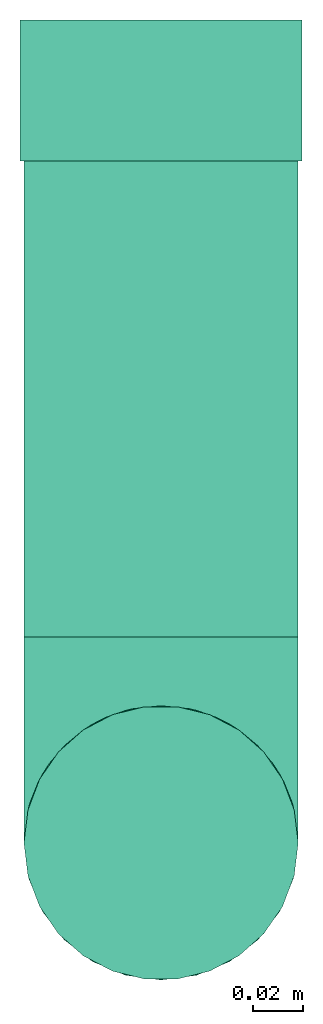
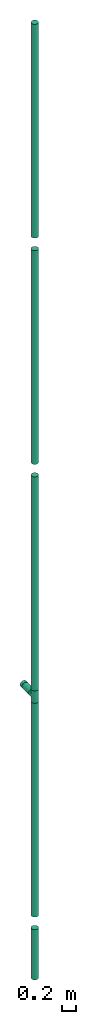
# One storey: 6 flow segments, 2 flow fittings.
"""IFC2X3 building model written with IfcOpenShell, lengths in millimetres."""

from ifc_helpers import new_model, entity, si_unit, converted_unit, derived_unit, direction, frame, frame_2d, origin, origin_2d_with_axis, place, context, subcontext, project, spatial, circle, extrude, faceted_brep, source, transform, mapped, type_object, type_shapes, element, save


model = new_model("IFC2X3")

# Units and contexts
model_context = context("Model", 3, precision=0.01, world=origin(), true_north=direction((6.12303176911189e-17, 1.0)))
body_context = subcontext(model_context, "Body", "Model", "MODEL_VIEW")
ifc_project = project(units=[si_unit("LENGTHUNIT", "METRE", prefix="MILLI"), si_unit("AREAUNIT", "SQUARE_METRE"), si_unit("VOLUMEUNIT", "CUBIC_METRE"), converted_unit("PLANEANGLEUNIT", "DEGREE", entity("IfcRatioMeasure", 0.0174532925199433), si_unit("PLANEANGLEUNIT", "RADIAN"), dimensions=[0, 0, 0, 0, 0, 0, 0]), si_unit("MASSUNIT", "GRAM", prefix="KILO"), derived_unit("MASSDENSITYUNIT", [(si_unit("MASSUNIT", "GRAM", prefix="KILO"), 1), (si_unit("LENGTHUNIT", "METRE"), -3)]), si_unit("TIMEUNIT", "SECOND"), si_unit("FREQUENCYUNIT", "HERTZ"), si_unit("THERMODYNAMICTEMPERATUREUNIT", "DEGREE_CELSIUS"), derived_unit("THERMALTRANSMITTANCEUNIT", [(si_unit("MASSUNIT", "GRAM", prefix="KILO"), 1), (si_unit("THERMODYNAMICTEMPERATUREUNIT", "KELVIN"), -1), (si_unit("TIMEUNIT", "SECOND"), -3)]), derived_unit("VOLUMETRICFLOWRATEUNIT", [(si_unit("LENGTHUNIT", "METRE"), 3), (si_unit("TIMEUNIT", "SECOND"), -1)]), si_unit("ELECTRICCURRENTUNIT", "AMPERE"), si_unit("ELECTRICVOLTAGEUNIT", "VOLT"), si_unit("POWERUNIT", "WATT"), si_unit("FORCEUNIT", "NEWTON", prefix="KILO"), si_unit("ILLUMINANCEUNIT", "LUX"), si_unit("LUMINOUSFLUXUNIT", "LUMEN"), si_unit("LUMINOUSINTENSITYUNIT", "CANDELA"), derived_unit("USERDEFINED", [(si_unit("MASSUNIT", "GRAM", prefix="KILO"), -1), (si_unit("LENGTHUNIT", "METRE"), -2), (si_unit("TIMEUNIT", "SECOND"), 3), (si_unit("LUMINOUSFLUXUNIT", "LUMEN"), 1)]), derived_unit("LINEARVELOCITYUNIT", [(si_unit("LENGTHUNIT", "METRE"), 1), (si_unit("TIMEUNIT", "SECOND"), -1)]), si_unit("PRESSUREUNIT", "PASCAL"), derived_unit("USERDEFINED", [(si_unit("LENGTHUNIT", "METRE"), -2), (si_unit("MASSUNIT", "GRAM", prefix="KILO"), 1), (si_unit("TIMEUNIT", "SECOND"), -2)])], contexts=[model_context])

# Site, building, storey
site_placement = place(None, origin())
site = spatial("IfcSite", under=ifc_project, at=site_placement, CompositionType="ELEMENT")
building_placement = place(site_placement, origin())
building = spatial("IfcBuilding", under=site, at=building_placement, CompositionType="ELEMENT")
storey_placement = place(building_placement, frame((0.0, 0.0, 4000.0)))
storey = spatial("IfcBuildingStorey", under=building, at=storey_placement, Name="01 Level", CompositionType="ELEMENT", Elevation=4000.0)

# Flow segments
pipe_segment_type = type_object("IfcPipeSegmentType", Name="Pipe Types", PredefinedType="NOTDEFINED")
flow_segment_1_placement = place(storey_placement, frame((30783.1932668086, -68217.4194628322, 9110.0)))
element("IfcFlowSegment", 1, at=flow_segment_1_placement, inside=storey, type_object=pipe_segment_type, Name="Pipe Types", ObjectType="Pipe Types", context=body_context, shape_type="SweptSolid", body=[
    extrude(circle(Radius=55.0, at=origin_2d_with_axis()), frame((56.5952722359164, 56.5952722359121, 0.0)), (0.0, 0.0, 1.0), 3780.0),
])
flow_segment_2_placement = place(storey_placement, frame((30783.1932668086, -68078.3241905963, 943.404727764084)))
element("IfcFlowSegment", 2, at=flow_segment_2_placement, inside=storey, type_object=pipe_segment_type, Name="Pipe Types", ObjectType="Pipe Types", context=body_context, shape_type="SweptSolid", body=[
    extrude(circle(Radius=55.0, at=origin_2d_with_axis()), frame((56.5952722359164, 0.0, 56.5952722359164), z_axis=(0.0, 1.0, 0.0), x_axis=(1.0, 0.0, 0.0)), (0.0, 0.0, 1.0), 190.972824049356),
])
flow_segment_3_placement = place(storey_placement, frame((30783.1932668086, -68217.4194628322, -4000.0)))
element("IfcFlowSegment", 3, at=flow_segment_3_placement, inside=storey, type_object=pipe_segment_type, Name="Pipe Types", ObjectType="Pipe Types", context=body_context, shape_type="SweptSolid", body=[
    extrude(circle(Radius=55.0, at=origin_2d_with_axis()), frame((56.5952722359164, 56.5952722359121, 0.0)), (0.0, 0.0, 1.0), 890.000000000002),
])
flow_segment_4_placement = place(storey_placement, frame((30783.1932668086, -68217.4194628322, -2890.0)))
element("IfcFlowSegment", 4, at=flow_segment_4_placement, inside=storey, type_object=pipe_segment_type, Name="Pipe Types", ObjectType="Pipe Types", context=body_context, shape_type="SweptSolid", body=[
    extrude(circle(Radius=55.0, at=origin_2d_with_axis()), frame((56.5952722359164, 56.5952722359121, 0.0)), (0.0, 0.0, 1.0), 3780.0),
])
for number, where, name in (
    (5, (30783.1932668086, -68217.4194628322, 1110.0), "Pipe Types"),
    (6, (30783.1932668086, -68217.4194628322, 5110.0), "Pipe Types"),
):
    element("IfcFlowSegment", number, at=place(storey_placement, frame(where)), inside=storey, type_object=pipe_segment_type, Name=name, ObjectType="Pipe Types", context=body_context, shape_type="SweptSolid", body=[
        extrude(circle(Radius=55.0, at=origin_2d_with_axis()), frame((56.5952722359164, 56.5952722359121, 0.0), z_axis=(0.0, 0.0, 1.0), x_axis=(-1.0, 0.0, 0.0)), (0.0, 0.0, 1.0), 3780.0),
    ])

# Flow fittings
pipe_fitting_type_1 = type_object("IfcPipeFittingType", Name="pipe_fe_tee_90_001", PredefinedType="NOTDEFINED")
shared_shape_1 = source(origin(), body_context, "Body", "Brep", [
    faceted_brep([(-110.0, 27.5000000000003, -47.6313972081441), (-110.0, 14.235047480639, -53.1259204458987), (-110.0, 0.0, -55.0), (-110.0, -14.2350474806383, -53.1259204458988), (-110.0, -27.4999999999996, -47.6313972081442), (-110.0, -33.1954364826297, -43.2611350867022), (-110.0, -38.8908729652597, -38.8908729652602), (-110.0, -43.2611350867018, -33.1954364826302), (-110.0, -47.6313972081438, -27.5000000000001), (-110.0, -50.3786588270211, -20.8675237403194), (-110.0, -53.1259204458984, -14.2350474806388), (-110.0, -54.0629602229491, -7.11752374031947), (-110.0, -55.0, 0.0), (-110.0, -54.0629602229492, 7.11752374031898), (-110.0, -53.1259204458986, 14.2350474806381), (-110.0, -50.3786588270214, 20.8675237403188), (-110.0, -47.6313972081441, 27.4999999999995), (-110.0, -43.2611350867022, 33.1954364826296), (-110.0, -38.8908729652602, 38.8908729652597), (-110.0, -33.1954364826302, 43.2611350867018), (-110.0, -27.5000000000002, 47.6313972081438), (-110.0, -14.2350474806389, 53.1259204458986), (-110.0, 0.0, 55.0), (-110.0, 14.2350474806383, 53.1259204458989), (-110.0, 27.4999999999997, 47.6313972081444), (-110.0, 38.8908729652599, 38.8908729652606), (-110.0, 47.6313972081441, 27.5000000000006), (-110.0, 53.1259204458989, 14.2350474806393), (-110.0, 55.0, 0.0), (-110.0, 53.125920445899, -14.2350474806386), (-110.0, 47.6313972081444, -27.5), (-110.0, 38.8908729652604, -38.8908729652601), (110.0, 0.0, -55.0), (110.0, 14.2350474806383, -53.1259204458987), (110.0, 27.4999999999996, -47.6313972081441), (110.0, 38.8908729652597, -38.8908729652601), (110.0, 47.6313972081437, -27.5), (110.0, 53.1259204458983, -14.2350474806386), (110.0, 55.0, 0.0), (110.0, 53.1259204458982, 14.2350474806393), (110.0, 47.6313972081434, 27.5000000000006), (110.0, 38.8908729652592, 38.8908729652606), (110.0, 27.499999999999, 47.6313972081444), (110.0, 14.2350474806376, 53.1259204458989), (110.0, 0.0, 55.0), (110.0, -14.2350474806396, 53.1259204458986), (110.0, -27.5000000000009, 47.6313972081438), (110.0, -33.1954364826309, 43.2611350867018), (110.0, -38.8908729652609, 38.8908729652597), (110.0, -43.2611350867029, 33.1954364826296), (110.0, -47.6313972081448, 27.4999999999995), (110.0, -50.3786588270221, 20.8675237403188), (110.0, -53.1259204458993, 14.2350474806381), (110.0, -54.0629602229499, 7.11752374031896), (110.0, -55.0, 0.0), (110.0, -54.0629602229498, -7.11752374031947), (110.0, -53.1259204458991, -14.2350474806388), (110.0, -50.3786588270218, -20.8675237403195), (110.0, -47.6313972081445, -27.5000000000001), (110.0, -43.2611350867024, -33.1954364826302), (110.0, -38.8908729652604, -38.8908729652602), (110.0, -33.1954364826304, -43.2611350867022), (110.0, -27.5000000000003, -47.6313972081442), (110.0, -14.235047480639, -53.1259204458988), (53.780443600281, -53.7804436002813, 11.5179809930815), (54.3902218001405, -54.3902218001408, 5.75899049654068), (50.3569451821954, -50.3569451821957, 22.1173703662385), (38.9627561846374, -38.9627561846376, 38.8188566356159), (31.8898295358707, -31.8898295358709, 44.8111456244214), (-54.3902218001406, -54.3902218001404, 5.75899049654068), (45.247564911309, -45.2475649113092, 31.267521001782), (-53.7804436002811, -53.780443600281, 11.5179809930815), (-50.3569451821955, -50.3569451821954, 22.1173703662384), (-55.0, -55.0, 0.0), (55.0, -55.0, 0.0), (-31.8898295358708, -31.8898295358708, 44.8111456244214), (-38.9627561846374, -38.9627561846373, 38.8188566356159), (-45.247564911309, -45.2475649113089, 31.267521001782), (-24.2945605988947, -24.2945605988946, 49.3434324435039), (24.2945605988946, -24.2945605988948, 49.3434324435039), (8.22722382923395, -8.22722382923404, 54.3811804585344), (16.3614781538201, -16.3614781538203, 52.510018402416), (0.0, 0.0, 55.0), (-8.227223829234, -8.22722382923398, 54.3811804585344), (-16.3614781538202, -16.3614781538202, 52.510018402416), (0.0, 0.0, -55.0), (8.22722382923376, -8.2272238292339, -54.3811804585344), (-54.3902218001405, -54.3902218001404, -5.75899049654098), (54.3902218001405, -54.3902218001407, -5.75899049654099), (-8.22722382923383, -8.22722382923384, -54.3811804585344), (16.36147815382, -16.3614781538201, -52.510018402416), (-45.2475649113089, -45.2475649113088, -31.2675210017822), (31.8898295358706, -31.8898295358708, -44.8111456244216), (-50.3569451821954, -50.3569451821952, -22.1173703662387), (-38.9627561846373, -38.9627561846372, -38.818856635616), (-31.8898295358707, -31.8898295358706, -44.8111456244215), (-16.36147815382, -16.36147815382, -52.510018402416), (-24.2945605988945, -24.2945605988944, -49.343432443504), (24.2945605988944, -24.2945605988946, -49.343432443504), (38.9627561846372, -38.9627561846374, -38.8188566356161), (-53.780443600281, -53.7804436002809, -11.5179809930818), (45.2475649113088, -45.2475649113091, -31.2675210017822), (50.3569451821953, -50.3569451821956, -22.1173703662387), (53.780443600281, -53.7804436002812, -11.5179809930818), (0.0, -82.4999999999999, -55.0), (14.2350474806387, -82.4999999999999, -53.1259204458987), (27.5, -82.4999999999999, -47.6313972081441), (38.8908729652601, -82.4999999999999, -38.8908729652601), (47.6313972081441, -82.4999999999999, -27.5), (53.1259204458987, -82.4999999999999, -14.2350474806386), (55.0, -82.4999999999999, 0.0), (53.1259204458986, -82.4999999999999, 14.2350474806393), (47.6313972081438, -82.4999999999999, 27.5000000000006), (38.8908729652596, -82.4999999999999, 38.8908729652606), (27.4999999999994, -82.4999999999999, 47.6313972081444), (14.235047480638, -82.4999999999999, 53.1259204458989), (0.0, -82.4999999999999, 55.0), (-14.2350474806392, -82.4999999999999, 53.1259204458986), (-27.5000000000005, -82.4999999999999, 47.6313972081438), (-38.8908729652605, -82.4999999999999, 38.8908729652597), (-47.6313972081444, -82.4999999999999, 27.4999999999995), (-53.1259204458989, -82.4999999999999, 14.2350474806381), (-55.0, -82.4999999999999, 0.0), (-53.1259204458987, -82.4999999999999, -14.2350474806388), (-47.6313972081441, -82.4999999999999, -27.5000000000001), (-38.8908729652601, -82.4999999999999, -38.8908729652602), (-27.4999999999999, -82.4999999999999, -47.6313972081442), (-14.2350474806386, -82.4999999999999, -53.1259204458988)], [[[0, 1, 2, 3, 4, 5, 6, 7, 8, 9, 10, 11, 12, 13, 14, 15, 16, 17, 18, 19, 20, 21, 22, 23, 24, 25, 26, 27, 28, 29, 30, 31]], [[32, 33, 34, 35, 36, 37, 38, 39, 40, 41, 42, 43, 44, 45, 46, 47, 48, 49, 50, 51, 52, 53, 54, 55, 56, 57, 58, 59, 60, 61, 62, 63]], [[53, 52, 64]], [[54, 53, 65]], [[66, 64, 52]], [[51, 50, 66, 52]], [[49, 48, 67]], [[68, 47, 46]], [[12, 69, 13]], [[70, 49, 67]], [[67, 48, 47]], [[70, 50, 49]], [[50, 70, 66]], [[67, 47, 68]], [[71, 72, 14]], [[13, 69, 71]], [[69, 12, 73]], [[54, 65, 74]], [[72, 16, 15, 14]], [[75, 19, 76]], [[76, 18, 17]], [[77, 17, 16]], [[76, 19, 18]], [[20, 75, 78]], [[77, 16, 72]], [[53, 64, 65]], [[68, 46, 79]], [[45, 44, 80]], [[71, 14, 13]], [[81, 79, 45]], [[80, 81, 45]], [[76, 17, 77]], [[80, 44, 82]], [[83, 82, 22]], [[45, 79, 46]], [[26, 25, 41, 40]], [[27, 26, 40, 39]], [[24, 23, 43, 42]], [[25, 24, 42, 41]], [[43, 23, 22, 82, 44]], [[28, 27, 39, 38]], [[84, 83, 21]], [[84, 21, 78]], [[21, 83, 22]], [[78, 21, 20]], [[75, 20, 19]], [[31, 30, 36, 35]], [[29, 37, 36, 30]], [[28, 38, 37, 29]], [[0, 31, 35, 34]], [[85, 2, 1, 33, 32]], [[86, 32, 63]], [[12, 87, 73]], [[54, 74, 88]], [[86, 85, 32]], [[2, 85, 89]], [[90, 86, 63]], [[91, 8, 7]], [[92, 62, 61]], [[34, 33, 1, 0]], [[93, 10, 9, 8]], [[94, 5, 95]], [[96, 97, 3]], [[89, 96, 3]], [[2, 89, 3]], [[97, 4, 3]], [[90, 63, 98]], [[60, 99, 61]], [[11, 100, 87]], [[92, 61, 99]], [[99, 60, 59]], [[59, 58, 101]], [[62, 92, 98]], [[102, 58, 57, 56]], [[103, 102, 56]], [[103, 55, 88]], [[58, 102, 101]], [[103, 56, 55]], [[94, 6, 5]], [[95, 4, 97]], [[95, 5, 4]], [[94, 91, 7]], [[94, 7, 6]], [[54, 88, 55]], [[99, 59, 101]], [[12, 11, 87]], [[93, 100, 10]], [[10, 100, 11]], [[93, 8, 91]], [[62, 98, 63]], [[104, 105, 106, 107, 108, 109, 110, 111, 112, 113, 114, 115, 116, 117, 118, 119, 120, 121, 122, 123, 124, 125, 126, 127]], [[122, 121, 71]], [[122, 71, 69, 73]], [[71, 121, 72]], [[119, 118, 75]], [[77, 120, 119]], [[72, 121, 120]], [[78, 118, 117]], [[77, 72, 120]], [[75, 76, 119]], [[77, 119, 76]], [[84, 78, 117]], [[116, 82, 83]], [[84, 117, 83]], [[75, 118, 78]], [[83, 117, 116]], [[114, 79, 115]], [[115, 80, 116]], [[68, 114, 113]], [[64, 111, 110]], [[113, 112, 70]], [[111, 66, 112]], [[110, 74, 65, 64]], [[68, 79, 114]], [[81, 80, 115]], [[79, 81, 115]], [[64, 66, 111]], [[70, 67, 113]], [[66, 70, 112]], [[68, 113, 67]], [[116, 80, 82]], [[110, 109, 103]], [[110, 103, 88, 74]], [[103, 109, 102]], [[101, 108, 107]], [[107, 106, 92]], [[102, 109, 108]], [[98, 106, 105]], [[101, 102, 108]], [[92, 99, 107]], [[101, 107, 99]], [[90, 98, 105]], [[104, 85, 86]], [[90, 105, 86]], [[92, 106, 98]], [[86, 105, 104]], [[126, 97, 127]], [[127, 89, 104]], [[95, 126, 125]], [[100, 123, 122]], [[125, 124, 91]], [[123, 93, 124]], [[122, 73, 87, 100]], [[95, 97, 126]], [[96, 89, 127]], [[97, 96, 127]], [[100, 93, 123]], [[91, 94, 125]], [[93, 91, 124]], [[95, 125, 94]], [[104, 89, 85]]]),
])
type_shapes(pipe_fitting_type_1, [shared_shape_1])
flow_fitting_1_placement = place(storey_placement, frame((30839.7885390445, -68160.8241905963, 1000.0), z_axis=(1.0, 0.0, 0.0), x_axis=(0.0, 0.0, 1.0)))
element("IfcFlowFitting", 7, at=flow_fitting_1_placement, inside=storey, type_object=pipe_fitting_type_1, Name="pipe_fe_tee_90_001:pipe_fe_tee_90_001", ObjectType="pipe_fe_tee_90_001:pipe_fe_tee_90_001", context=body_context, shape_type="MappedRepresentation", body=[
    mapped(shared_shape_1, transform((0.0, 0.0, 0.0), scale=1.0)),
])
pipe_fitting_type_2 = type_object("IfcPipeFittingType", Name="Standard", PredefinedType="NOTDEFINED")
shared_shape_2 = source(origin(), body_context, "Body", "SweptSolid", [
    extrude(circle(Radius=56.5875, at=frame_2d((0.0, -9.1419628605704e-14), x_axis=(1.0, 0.0))), frame((-28.2937499999937, 0.0, 0.0), z_axis=(1.0, 0.0, 0.0), x_axis=(0.0, 1.0, 0.0)), (0.0, 0.0, 1.0), 56.5875),
])
type_shapes(pipe_fitting_type_2, [shared_shape_2])
flow_fitting_2_placement = place(storey_placement, frame((30839.7885390445, -67859.057616547, 1000.0), z_axis=(0.0, 0.0, 1.0), x_axis=(0.0, 1.0, 0.0)))
element("IfcFlowFitting", 8, at=flow_fitting_2_placement, inside=storey, type_object=pipe_fitting_type_2, Name="M_Coupling - Generic:Standard", ObjectType="M_Coupling - Generic:Standard", context=body_context, shape_type="MappedRepresentation", body=[
    mapped(shared_shape_2, transform((0.0, 0.0, 0.0), scale=1.0)),
])

save(model, "model.ifc")
